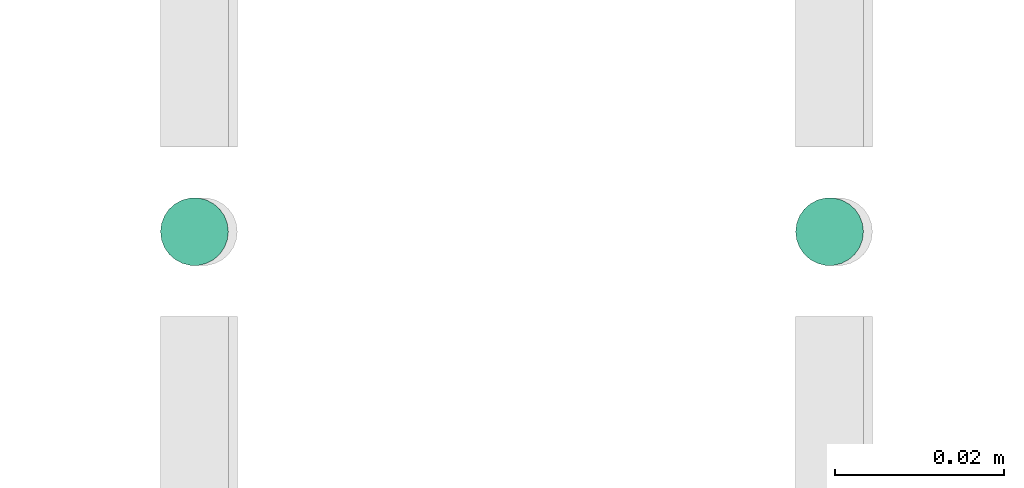
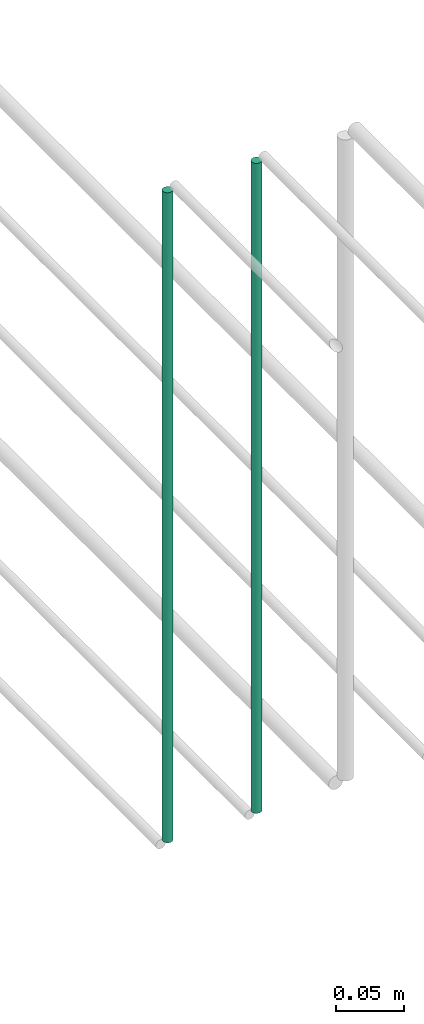
# One storey, part 174 of 331: 2 flow segments.
"""IFC2X3 building model written with IfcOpenShell, lengths in millimetres."""

from ifc_helpers import new_model, entity, si_unit, converted_unit, derived_unit, direction, frame, origin, origin_2d_with_axis, place, context, subcontext, project, spatial, circle, extrude, type_object, element, save


model = new_model("IFC2X3")

# Units and contexts
model_context = context("Model", 3, precision=0.01, world=origin(), true_north=direction((6.12303176911189e-17, 1.0)))
body_context = subcontext(model_context, "Body", "Model", "MODEL_VIEW")
ifc_project = project(units=[si_unit("LENGTHUNIT", "METRE", prefix="MILLI"), si_unit("AREAUNIT", "SQUARE_METRE"), si_unit("VOLUMEUNIT", "CUBIC_METRE"), converted_unit("PLANEANGLEUNIT", "DEGREE", entity("IfcRatioMeasure", 0.0174532925199433), si_unit("PLANEANGLEUNIT", "RADIAN"), dimensions=[0, 0, 0, 0, 0, 0, 0]), si_unit("MASSUNIT", "GRAM", prefix="KILO"), derived_unit("MASSDENSITYUNIT", [(si_unit("MASSUNIT", "GRAM", prefix="KILO"), 1), (si_unit("LENGTHUNIT", "METRE"), -3)]), derived_unit("MOMENTOFINERTIAUNIT", [(si_unit("LENGTHUNIT", "METRE"), 4)]), si_unit("TIMEUNIT", "SECOND"), si_unit("FREQUENCYUNIT", "HERTZ"), si_unit("THERMODYNAMICTEMPERATUREUNIT", "DEGREE_CELSIUS"), derived_unit("THERMALTRANSMITTANCEUNIT", [(si_unit("MASSUNIT", "GRAM", prefix="KILO"), 1), (si_unit("THERMODYNAMICTEMPERATUREUNIT", "KELVIN"), -1), (si_unit("TIMEUNIT", "SECOND"), -3)]), derived_unit("VOLUMETRICFLOWRATEUNIT", [(si_unit("LENGTHUNIT", "METRE"), 3), (si_unit("TIMEUNIT", "SECOND"), -1)]), derived_unit("MASSFLOWRATEUNIT", [(si_unit("MASSUNIT", "GRAM", prefix="KILO"), 1), (si_unit("TIMEUNIT", "SECOND"), -1)]), derived_unit("ROTATIONALFREQUENCYUNIT", [(si_unit("TIMEUNIT", "SECOND"), -1)]), si_unit("ELECTRICCURRENTUNIT", "AMPERE"), si_unit("ELECTRICVOLTAGEUNIT", "VOLT"), si_unit("POWERUNIT", "WATT"), si_unit("FORCEUNIT", "NEWTON", prefix="KILO"), si_unit("ILLUMINANCEUNIT", "LUX"), si_unit("LUMINOUSFLUXUNIT", "LUMEN"), si_unit("LUMINOUSINTENSITYUNIT", "CANDELA"), derived_unit("USERDEFINED", [(si_unit("MASSUNIT", "GRAM", prefix="KILO"), -1), (si_unit("LENGTHUNIT", "METRE"), -2), (si_unit("TIMEUNIT", "SECOND"), 3), (si_unit("LUMINOUSFLUXUNIT", "LUMEN"), 1)]), derived_unit("LINEARVELOCITYUNIT", [(si_unit("LENGTHUNIT", "METRE"), 1), (si_unit("TIMEUNIT", "SECOND"), -1)]), si_unit("PRESSUREUNIT", "PASCAL"), derived_unit("USERDEFINED", [(si_unit("LENGTHUNIT", "METRE"), -2), (si_unit("MASSUNIT", "GRAM", prefix="KILO"), 1), (si_unit("TIMEUNIT", "SECOND"), -2)]), derived_unit("LINEARFORCEUNIT", [(si_unit("MASSUNIT", "GRAM", prefix="KILO"), 1), (si_unit("LENGTHUNIT", "METRE"), 1), (si_unit("TIMEUNIT", "SECOND"), -2), (si_unit("LENGTHUNIT", "METRE"), -1)]), derived_unit("PLANARFORCEUNIT", [(si_unit("MASSUNIT", "GRAM", prefix="KILO"), 1), (si_unit("LENGTHUNIT", "METRE"), 1), (si_unit("TIMEUNIT", "SECOND"), -2), (si_unit("LENGTHUNIT", "METRE"), -2)])], contexts=[model_context])

# Site, building, storey
site_placement = place(None, frame((0.0, -0.00077364408347762, 0.0)))
site = spatial("IfcSite", under=ifc_project, at=site_placement, CompositionType="ELEMENT")
building_placement = place(site_placement, origin())
building = spatial("IfcBuilding", under=site, at=building_placement, CompositionType="ELEMENT")
storey_placement = place(building_placement, origin())
storey = spatial("IfcBuildingStorey", under=building, at=storey_placement, CompositionType="ELEMENT", Elevation=0.0)

# Flow segments
pipe_segment_type = type_object("IfcPipeSegmentType", PredefinedType="NOTDEFINED")
flow_segment_1_placement = place(storey_placement, frame((43464.4468045266, 5638.02529159143, 18460.0)))
element("IfcFlowSegment", 1, at=flow_segment_1_placement, inside=storey, type_object=pipe_segment_type, context=body_context, shape_type="SweptSolid", body=[
    extrude(circle(Radius=4.0, at=origin_2d_with_axis()), frame((5.59527223591499, 5.59527223591607, 0.0), z_axis=(0.0, 0.0, 1.0), x_axis=(-1.0, 0.0, 0.0)), (0.0, 0.0, 1.0), 580.000000000015),
])
flow_segment_2_placement = place(storey_placement, frame((43539.4468045266, 5638.02529159143, 18460.0)))
element("IfcFlowSegment", 2, at=flow_segment_2_placement, inside=storey, type_object=pipe_segment_type, context=body_context, shape_type="SweptSolid", body=[
    extrude(circle(Radius=4.0, at=origin_2d_with_axis()), frame((5.59527223591499, 5.59527223591607, 0.0), z_axis=(0.0, 0.0, 1.0), x_axis=(-1.0, 0.0, 0.0)), (0.0, 0.0, 1.0), 580.000000000007),
])

save(model, "model.ifc")
